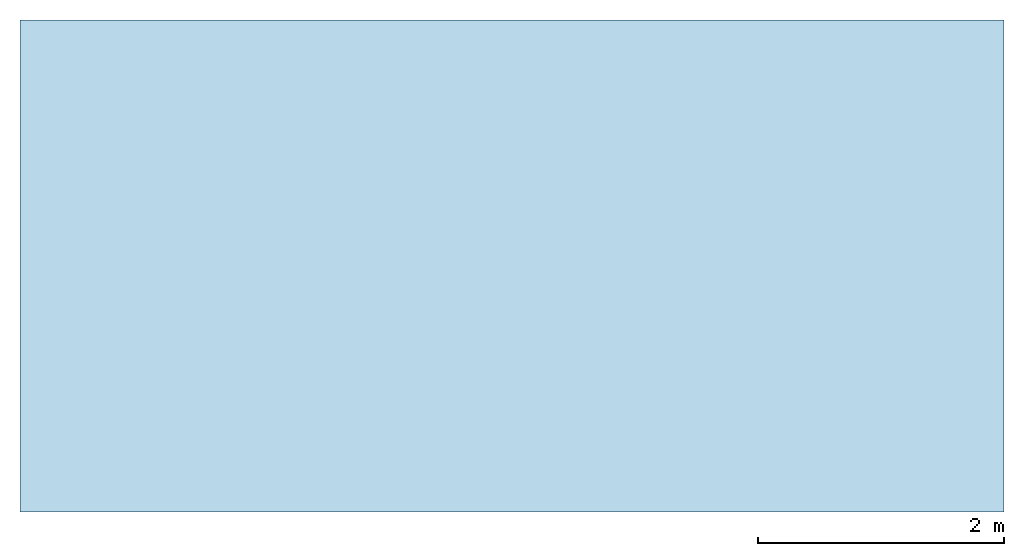
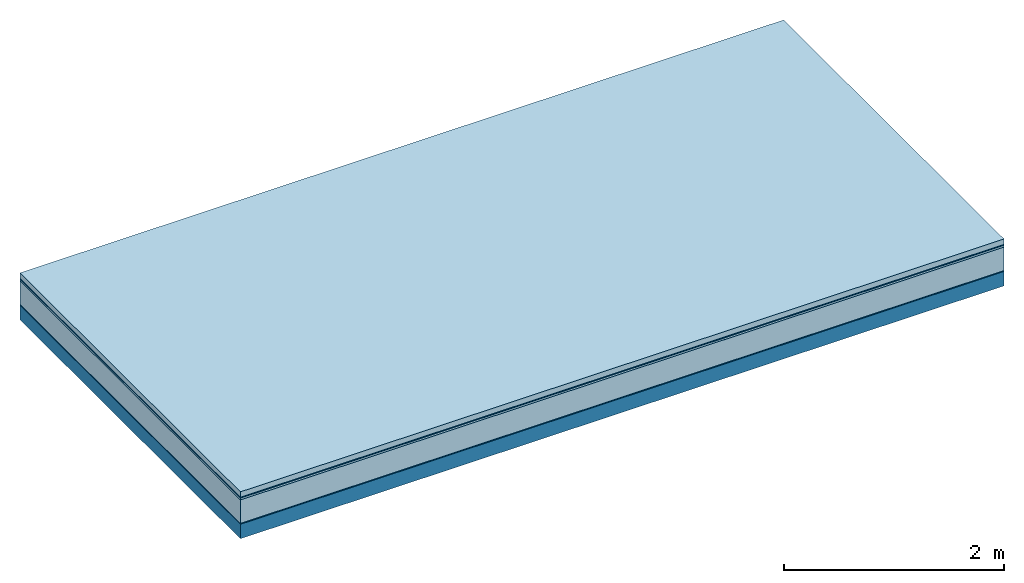
# One storey: 5 plates, 1 member, 1 element without a shape of its own.
"""IFC4 building model written with IfcOpenShell, lengths in metres."""

from ifc_helpers import new_model, si_unit, derived_unit, direction, frame, frame_2d, origin, origin_with_axes, place, context, project, spatial, rectangle, extrude, material, layer, layer_set, type_object, element, aggregate, save


model = new_model("IFC4")

# Units and contexts
plan_context = context("Plan", 3, precision=1e-05, world=origin(), true_north=direction((0.0, 1.0)))
model_context = context("Model", 3, precision=1e-05, world=origin(), true_north=direction((0.0, 1.0)))
ifc_project = project(units=[si_unit("LENGTHUNIT", "METRE"), derived_unit("SOUNDPRESSUREUNIT", [(si_unit("PRESSUREUNIT", "PASCAL", prefix="MICRO"), 0)]), si_unit("ENERGYUNIT", "JOULE", prefix="MEGA"), si_unit("MASSUNIT", "GRAM", prefix="KILO"), derived_unit("THERMALTRANSMITTANCEUNIT", [(si_unit("POWERUNIT", "WATT"), 1), (si_unit("AREAUNIT", "SQUARE_METRE"), -1), (si_unit("THERMODYNAMICTEMPERATUREUNIT", "KELVIN"), -1)]), derived_unit("AREADENSITYUNIT", [(si_unit("MASSUNIT", "GRAM", prefix="KILO"), 1), (si_unit("AREAUNIT", "SQUARE_METRE"), -1)]), derived_unit("USERDEFINED", [(si_unit("ENERGYUNIT", "JOULE", prefix="MEGA"), 1), (si_unit("AREAUNIT", "SQUARE_METRE"), -1)])], contexts=[plan_context, model_context])

# Site, building, storey
site = spatial("IfcSite", under=ifc_project)
building_placement = place(None, origin())
building = spatial("IfcBuilding", under=site, at=building_placement)
storey_placement = place(building_placement, origin())
storey = spatial("IfcBuildingStorey", under=building, at=storey_placement)

# Slab, member, plates
ifc_material_1 = material(Name="clay", Category="02.004")
ifc_layer_1 = layer(ifc_material_1, 0.06, Name="Use and protection layer 2")
ifc_material_2 = material(Name="Protective layer", Category="09.007")
ifc_layer_2 = layer(ifc_material_2, 0.01, Name="Use and protection layer 1")
ifc_material_3 = material(Name="Bituminous", Category="09.003")
ifc_layer_3 = layer(ifc_material_3, 0.02, Name="Seal")
ifc_material_4 = material(Name="Mineral wool", Category="10.008")
ifc_layer_4 = layer(ifc_material_4, 0.26, Name="Exterior insulation layer 1")
ifc_material_5 = material(Name="Vapor-permeable barrier", Category="09.006")
ifc_layer_5 = layer(ifc_material_5, 0.01, Name="layer / temporary roof")
ifc_material_6 = material(Name="no composite action")
ifc_layer_6 = layer(ifc_material_6, 0.0, Name="Bond")
ifc_layer_7 = layer(None, 0.16, Name="Support")
ifc_layer_set = layer_set([ifc_layer_1, ifc_layer_2, ifc_layer_3, ifc_layer_4, ifc_layer_5, ifc_layer_6, ifc_layer_7])
slab_type = type_object("IfcSlabType", Name="F0056", PredefinedType="NOTDEFINED", material=ifc_layer_set)
slab_placement = place(None, frame((0.0, 0.0, 0.0), z_axis=(0.0, 0.0, -1.0), x_axis=(1.0, 0.0, 0.0)))
slab = element("IfcSlab", 1, at=slab_placement, inside=storey, type_object=slab_type, material=ifc_layer_set, Name="Slab #1")
ifc_material_7 = material(Name="Solid timber panel")
member_placement = place(slab_placement, origin())
member = element("IfcMember", 2, at=member_placement, material=ifc_material_7, Name="Support", context=plan_context, shape_type="SweptSolid", body=[
    extrude(rectangle(XDim=1.0, YDim=0.16, at=frame_2d((0.5, 0.08), x_axis=(1.0, 0.0))), frame((0.0, 4.0, 0.36), z_axis=(0.0, -1.0, 0.0), x_axis=(1.0, 0.0, 0.0)), (0.0, 0.0, 1.0), 4.0),
    extrude(rectangle(XDim=1.0, YDim=0.16, at=frame_2d((0.5, 0.08), x_axis=(1.0, 0.0))), frame((1.0, 4.0, 0.36), z_axis=(0.0, -1.0, 0.0), x_axis=(1.0, 0.0, 0.0)), (0.0, 0.0, 1.0), 4.0),
    extrude(rectangle(XDim=1.0, YDim=0.16, at=frame_2d((0.5, 0.08), x_axis=(1.0, 0.0))), frame((2.0, 4.0, 0.36), z_axis=(0.0, -1.0, 0.0), x_axis=(1.0, 0.0, 0.0)), (0.0, 0.0, 1.0), 4.0),
    extrude(rectangle(XDim=1.0, YDim=0.16, at=frame_2d((0.5, 0.08), x_axis=(1.0, 0.0))), frame((3.0, 4.0, 0.36), z_axis=(0.0, -1.0, 0.0), x_axis=(1.0, 0.0, 0.0)), (0.0, 0.0, 1.0), 4.0),
    extrude(rectangle(XDim=1.0, YDim=0.16, at=frame_2d((0.5, 0.08), x_axis=(1.0, 0.0))), frame((4.0, 4.0, 0.36), z_axis=(0.0, -1.0, 0.0), x_axis=(1.0, 0.0, 0.0)), (0.0, 0.0, 1.0), 4.0),
    extrude(rectangle(XDim=1.0, YDim=0.16, at=frame_2d((0.5, 0.08), x_axis=(1.0, 0.0))), frame((5.0, 4.0, 0.36), z_axis=(0.0, -1.0, 0.0), x_axis=(1.0, 0.0, 0.0)), (0.0, 0.0, 1.0), 4.0),
    extrude(rectangle(XDim=1.0, YDim=0.16, at=frame_2d((0.5, 0.08), x_axis=(1.0, 0.0))), frame((6.0, 4.0, 0.36), z_axis=(0.0, -1.0, 0.0), x_axis=(1.0, 0.0, 0.0)), (0.0, 0.0, 1.0), 4.0),
    extrude(rectangle(XDim=1.0, YDim=0.16, at=frame_2d((0.5, 0.08), x_axis=(1.0, 0.0))), frame((7.0, 4.0, 0.36), z_axis=(0.0, -1.0, 0.0), x_axis=(1.0, 0.0, 0.0)), (0.0, 0.0, 1.0), 4.0),
])
plate_1_placement = place(slab_placement, origin())
plate_1 = element("IfcPlate", 3, at=plate_1_placement, material=ifc_material_1, Name="Use and protection layer 2", context=plan_context, shape_type="SweptSolid", body=[
    extrude(rectangle(XDim=8.0, YDim=4.0, at=frame_2d((4.0, 2.0), x_axis=(1.0, 0.0))), origin_with_axes(), (0.0, 0.0, 1.0), 0.06),
])
plate_2_placement = place(slab_placement, origin())
plate_2 = element("IfcPlate", 4, at=plate_2_placement, material=ifc_material_2, Name="Use and protection layer 1", context=plan_context, shape_type="SweptSolid", body=[
    extrude(rectangle(XDim=8.0, YDim=4.0, at=frame_2d((4.0, 2.0), x_axis=(1.0, 0.0))), frame((0.0, 0.0, 0.06), z_axis=(0.0, 0.0, 1.0), x_axis=(1.0, 0.0, 0.0)), (0.0, 0.0, 1.0), 0.01),
])
plate_3_placement = place(slab_placement, origin())
plate_3 = element("IfcPlate", 5, at=plate_3_placement, material=ifc_material_3, Name="Seal", context=plan_context, shape_type="SweptSolid", body=[
    extrude(rectangle(XDim=8.0, YDim=4.0, at=frame_2d((4.0, 2.0), x_axis=(1.0, 0.0))), frame((0.0, 0.0, 0.07), z_axis=(0.0, 0.0, 1.0), x_axis=(1.0, 0.0, 0.0)), (0.0, 0.0, 1.0), 0.02),
])
plate_4_placement = place(slab_placement, origin())
plate_4 = element("IfcPlate", 6, at=plate_4_placement, material=ifc_material_4, Name="Exterior insulation layer 1", context=plan_context, shape_type="SweptSolid", body=[
    extrude(rectangle(XDim=8.0, YDim=4.0, at=frame_2d((4.0, 2.0), x_axis=(1.0, 0.0))), frame((0.0, 0.0, 0.09), z_axis=(0.0, 0.0, 1.0), x_axis=(1.0, 0.0, 0.0)), (0.0, 0.0, 1.0), 0.26),
])
plate_5_placement = place(slab_placement, origin())
plate_5 = element("IfcPlate", 7, at=plate_5_placement, material=ifc_material_5, Name="layer / temporary roof", context=plan_context, shape_type="SweptSolid", body=[
    extrude(rectangle(XDim=8.0, YDim=4.0, at=frame_2d((4.0, 2.0), x_axis=(1.0, 0.0))), frame((0.0, 0.0, 0.35), z_axis=(0.0, 0.0, 1.0), x_axis=(1.0, 0.0, 0.0)), (0.0, 0.0, 1.0), 0.01),
])
aggregate(slab, [plate_1, plate_2, plate_3, plate_4, plate_5, member])

save(model, "model.ifc")
